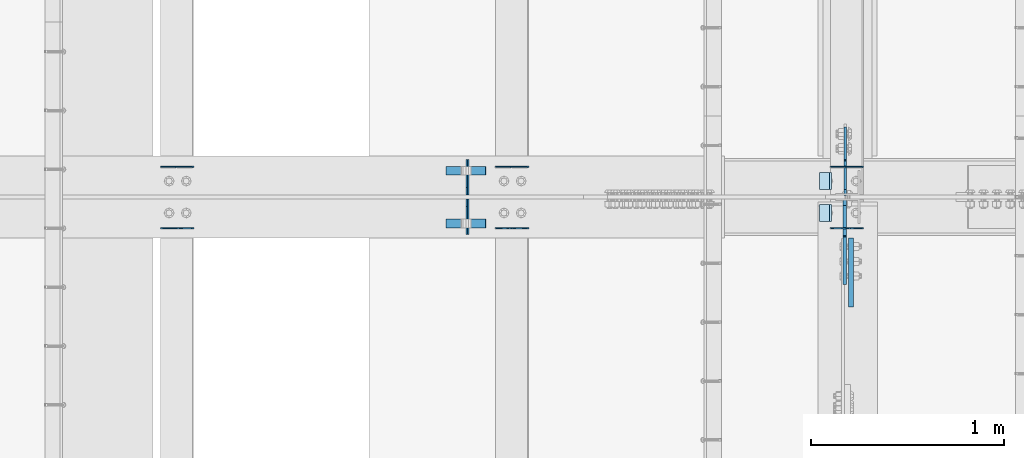
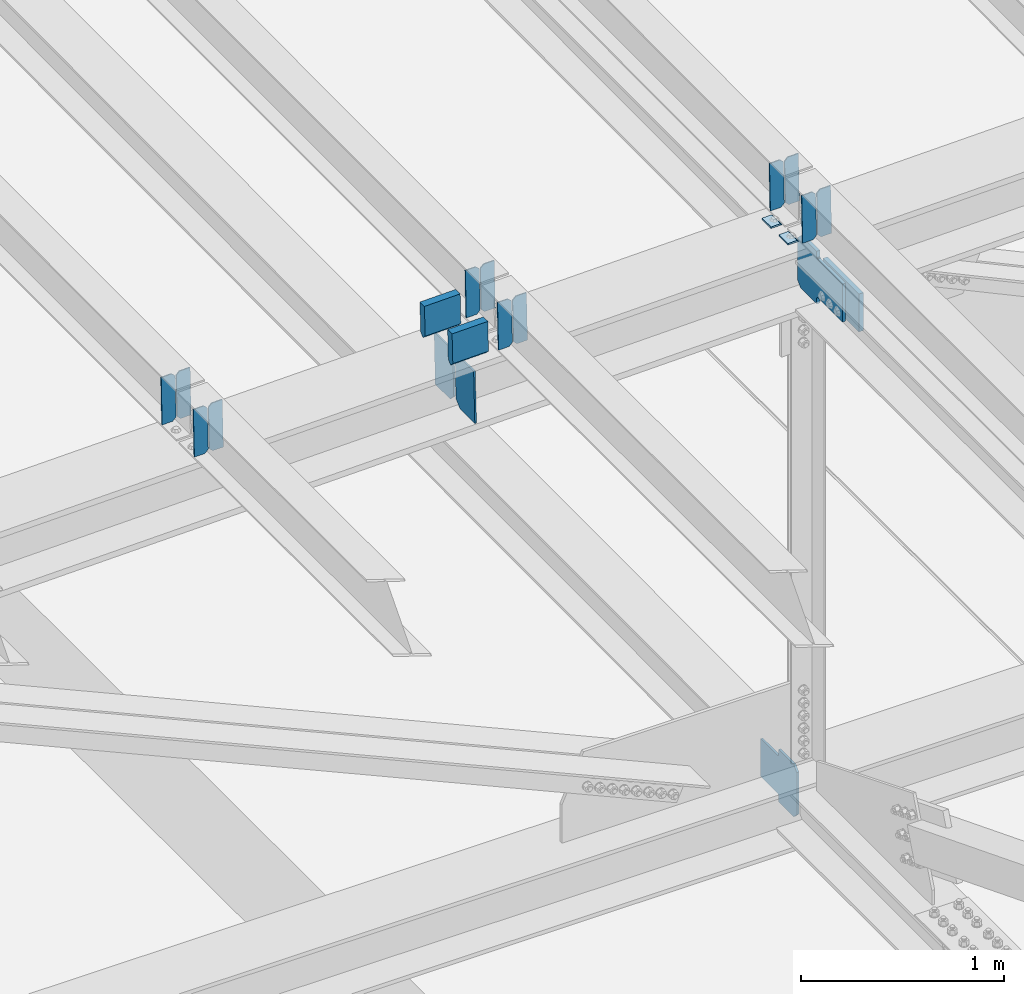
# One storey, part 3289 of 3843: 21 plates, 9 elements without a shape of their own.
"""IFC2X3 building model written with IfcOpenShell, lengths in millimetres."""

from ifc_helpers import new_model, si_unit, frame, origin_with_axes, place, context, subcontext, project, spatial, faceted_brep, material, type_object, element, aggregate, save


model = new_model("IFC2X3")

# Units and contexts
model_context = context("Model", 3, precision=1e-05, world=origin_with_axes())
body_context = subcontext(model_context, "Body", "Model", "MODEL_VIEW")
ifc_project = project(units=[si_unit("LENGTHUNIT", "METRE", prefix="MILLI"), si_unit("AREAUNIT", "SQUARE_METRE"), si_unit("VOLUMEUNIT", "CUBIC_METRE"), si_unit("MASSUNIT", "GRAM", prefix="KILO"), si_unit("TIMEUNIT", "SECOND"), si_unit("PLANEANGLEUNIT", "RADIAN"), si_unit("SOLIDANGLEUNIT", "STERADIAN"), si_unit("THERMODYNAMICTEMPERATUREUNIT", "DEGREE_CELSIUS"), si_unit("LUMINOUSINTENSITYUNIT", "LUMEN")], contexts=[model_context])

# Site, building, storey
site_placement = place(None, origin_with_axes())
site = spatial("IfcSite", under=ifc_project, at=site_placement, CompositionType="ELEMENT")
building_placement = place(site_placement, origin_with_axes())
building = spatial("IfcBuilding", under=site, at=building_placement, Name="Undefined", CompositionType="ELEMENT")
storey_placement = place(building_placement, origin_with_axes())
storey = spatial("IfcBuildingStorey", under=building, at=storey_placement, Name="Undefined", CompositionType="ELEMENT", Elevation=0.0)

# Assembly, plates
assembly_1_placement = place(storey_placement, origin_with_axes())
assembly_1 = element("IfcElementAssembly", 1, at=assembly_1_placement, inside=storey, Name="BEAM", AssemblyPlace="NOTDEFINED", PredefinedType="RIGID_FRAME")
ifc_material = material(Name="STEEL/A572-50")
plate_type_1 = type_object("IfcPlateType", PredefinedType="NOTDEFINED")
plate_1_placement = place(assembly_1_placement, frame((49078.8964783467, 34002.7083470369, 45700.8681200781), z_axis=(-0.0211520981022549, -0.00549162299942689, 0.999761186895503), x_axis=(-0.999776269345233, 0.000116185000071389, -0.0211517790072879)))
plate_1 = element("IfcPlate", 2, at=plate_1_placement, type_object=plate_type_1, material=ifc_material, Name="PLATE", context=body_context, shape_type="Brep", body=[
    faceted_brep([(0.0, -3.17499999999927, 0.0), (6.83940015733242e-10, -3.17499999996653, 288.924999998613), (6.54836185276508e-10, 3.17500000001746, 288.924999998591), (0.0, 3.17499999999927, 0.0), (60.3250007643655, -3.17500000017753, 288.924999998606), (60.3250007643219, 3.17499999979918, 288.924999998584), (79.3750000013097, -3.17500000025029, 269.875000761494), (79.375000001266, 3.17499999972642, 269.875000761487), (79.375000000713, -3.17500000026484, 19.0499992370605), (79.3750000006985, 3.17499999971187, 19.0499992370533), (60.325000763667, -3.17500000020664, -1.45519152283669e-11), (60.3250007636234, 3.17499999977736, -3.63797880709171e-11)], [[[0, 1, 2, 3]], [[1, 4, 5, 2]], [[4, 6, 7, 5]], [[6, 8, 9, 7]], [[8, 10, 11, 9]], [[10, 0, 3, 11]], [[5, 7, 9, 11, 3, 2]], [[10, 8, 6, 4, 1, 0]]]),
])
plate_2_placement = place(assembly_1_placement, frame((48993.1906576571, 34002.7183070254, 45699.0548838318), z_axis=(-0.0211520981022549, -0.00549162299942689, 0.999761186895503), x_axis=(-0.999776269345233, 0.000116185000071389, -0.0211517790072879)))
plate_2 = element("IfcPlate", 3, at=plate_2_placement, type_object=plate_type_1, material=ifc_material, Name="PLATE", context=body_context, shape_type="Brep", body=[
    faceted_brep([(4.36557456851006e-11, -3.17499999998836, 19.0499992370969), (6.11180439591408e-10, -3.17499999996653, 269.875000761516), (5.96628524363041e-10, 3.17500000001746, 269.875000761502), (1.45519152283669e-11, 3.17499999998836, 19.0499992370824), (19.0499992376572, -3.17500000003201, 288.924999998606), (19.0499992376281, 3.1749999999447, 288.924999998584), (79.3750000013242, -3.17500000025029, 288.924999998591), (79.3750000013097, 3.1749999997337, 288.92499999857), (79.3750000006548, -3.17500000026484, -2.18278728425503e-11), (79.3750000006403, 3.17499999969732, -2.91038304567337e-11), (19.0499992370023, -3.17500000005384, 0.0), (19.0499992369587, 3.17499999992287, -1.45519152283669e-11)], [[[0, 1, 2, 3]], [[1, 4, 5, 2]], [[4, 6, 7, 5]], [[6, 8, 9, 7]], [[8, 10, 11, 9]], [[10, 0, 3, 11]], [[5, 7, 9, 11, 3, 2]], [[10, 8, 6, 4, 1, 0]]]),
])

assembly_2_placement = place(storey_placement, origin_with_axes())
assembly_2 = element("IfcElementAssembly", 4, at=assembly_2_placement, inside=storey, Name="BEAM", AssemblyPlace="NOTDEFINED", PredefinedType="RIGID_FRAME")
plate_3_placement = place(assembly_2_placement, frame((49078.8964782632, 33683.7772628472, 45699.8947534283), z_axis=(-0.0211520978689295, -0.000677819999713391, 0.99977603957876), x_axis=(-0.99977626935017, 1.43409999980804e-05, -0.021152093007374)))
plate_3 = element("IfcPlate", 5, at=plate_3_placement, type_object=plate_type_1, material=ifc_material, Name="PLATE", context=body_context, shape_type="Brep", body=[
    faceted_brep([(0.0, -3.17499999999927, 0.0), (6.83940015733242e-10, -3.17499999996653, 288.924999998613), (6.54836185276508e-10, 3.17500000001746, 288.924999998591), (0.0, 3.17499999999927, 0.0), (60.3250007643655, -3.17500000017753, 288.924999998606), (60.3250007643219, 3.17499999979918, 288.924999998584), (79.3750000013097, -3.17500000025029, 269.875000761494), (79.375000001266, 3.17499999972642, 269.875000761487), (79.375000000713, -3.17500000026484, 19.0499992370605), (79.3750000006985, 3.17499999971187, 19.0499992370533), (60.325000763667, -3.17500000020664, -1.45519152283669e-11), (60.3250007636234, 3.17499999977736, -3.63797880709171e-11)], [[[0, 1, 2, 3]], [[1, 4, 5, 2]], [[4, 6, 7, 5]], [[6, 8, 9, 7]], [[8, 10, 11, 9]], [[10, 0, 3, 11]], [[5, 7, 9, 11, 3, 2]], [[10, 8, 6, 4, 1, 0]]]),
])
plate_4_placement = place(assembly_2_placement, frame((48993.1906575735, 33683.7784921894, 45698.0814902443), z_axis=(-0.0211520978689295, -0.000677819999713391, 0.99977603957876), x_axis=(-0.99977626935017, 1.43409999980804e-05, -0.021152093007374)))
plate_4 = element("IfcPlate", 6, at=plate_4_placement, type_object=plate_type_1, material=ifc_material, Name="PLATE", context=body_context, shape_type="Brep", body=[
    faceted_brep([(4.36557456851006e-11, -3.17499999998836, 19.0499992370969), (6.11180439591408e-10, -3.17499999996653, 269.875000761516), (5.96628524363041e-10, 3.17500000001746, 269.875000761502), (1.45519152283669e-11, 3.17499999998836, 19.0499992370824), (19.0499992376572, -3.17500000003201, 288.924999998606), (19.0499992376281, 3.1749999999447, 288.924999998584), (79.3750000013242, -3.17500000025029, 288.924999998591), (79.3750000013097, 3.1749999997337, 288.92499999857), (79.3750000006548, -3.17500000026484, -2.18278728425503e-11), (79.3750000006403, 3.17499999969732, -2.91038304567337e-11), (19.0499992370023, -3.17500000005384, 0.0), (19.0499992369587, 3.17499999992287, -1.45519152283669e-11)], [[[0, 1, 2, 3]], [[1, 4, 5, 2]], [[4, 6, 7, 5]], [[6, 8, 9, 7]], [[8, 10, 11, 9]], [[10, 0, 3, 11]], [[5, 7, 9, 11, 3, 2]], [[10, 8, 6, 4, 1, 0]]]),
])

assembly_3_placement = place(storey_placement, origin_with_axes())
assembly_3 = element("IfcElementAssembly", 7, at=assembly_3_placement, inside=storey, Name="BEAM", AssemblyPlace="NOTDEFINED", PredefinedType="RIGID_FRAME")
plate_5_placement = place(assembly_3_placement, frame((47345.3464782607, 34002.537154914, 45663.263665299), z_axis=(-0.0211520975680761, -0.00491457500028629, 0.999764190057354), x_axis=(-0.999776269348186, 0.0001032410000617, -0.0211518460073737)))
plate_5 = element("IfcPlate", 8, at=plate_5_placement, type_object=plate_type_1, material=ifc_material, Name="PLATE", context=body_context, shape_type="Brep", body=[
    faceted_brep([(0.0, -3.17499999999927, 0.0), (6.83940015733242e-10, -3.17499999996653, 288.924999998613), (6.54836185276508e-10, 3.17500000001746, 288.924999998591), (0.0, 3.17499999999927, 0.0), (60.3250007643655, -3.17500000017753, 288.924999998606), (60.3250007643219, 3.17499999979918, 288.924999998584), (79.3750000013097, -3.17500000025029, 269.875000761494), (79.375000001266, 3.17499999972642, 269.875000761487), (79.375000000713, -3.17500000026484, 19.0499992370605), (79.3750000006985, 3.17499999971187, 19.0499992370533), (60.325000763667, -3.17500000020664, -1.45519152283669e-11), (60.3250007636234, 3.17499999977736, -3.63797880709171e-11)], [[[0, 1, 2, 3]], [[1, 4, 5, 2]], [[4, 6, 7, 5]], [[6, 8, 9, 7]], [[8, 10, 11, 9]], [[10, 0, 3, 11]], [[5, 7, 9, 11, 3, 2]], [[10, 8, 6, 4, 1, 0]]]),
])
plate_6_placement = place(assembly_3_placement, frame((47259.6406575714, 34002.5460683283, 45661.450423606), z_axis=(-0.0211520975680761, -0.00491457500028629, 0.999764190057354), x_axis=(-0.999776269348186, 0.0001032410000617, -0.0211518460073737)))
plate_6 = element("IfcPlate", 9, at=plate_6_placement, type_object=plate_type_1, material=ifc_material, Name="PLATE", context=body_context, shape_type="Brep", body=[
    faceted_brep([(4.36557456851006e-11, -3.17499999998836, 19.0499992370969), (6.11180439591408e-10, -3.17499999996653, 269.875000761516), (5.96628524363041e-10, 3.17500000001746, 269.875000761502), (1.45519152283669e-11, 3.17499999998836, 19.0499992370824), (19.0499992376572, -3.17500000003201, 288.924999998606), (19.0499992376281, 3.1749999999447, 288.924999998584), (79.3750000013242, -3.17500000025029, 288.924999998591), (79.3750000013097, 3.1749999997337, 288.92499999857), (79.3750000006548, -3.17500000026484, -2.18278728425503e-11), (79.3750000006403, 3.17499999969732, -2.91038304567337e-11), (19.0499992370023, -3.17500000005384, 0.0), (19.0499992369587, 3.17499999992287, -1.45519152283669e-11)], [[[0, 1, 2, 3]], [[1, 4, 5, 2]], [[4, 6, 7, 5]], [[6, 8, 9, 7]], [[8, 10, 11, 9]], [[10, 0, 3, 11]], [[5, 7, 9, 11, 3, 2]], [[10, 8, 6, 4, 1, 0]]]),
])
aggregate(assembly_3, [plate_5, plate_6])

assembly_4_placement = place(storey_placement, origin_with_axes())
assembly_4 = element("IfcElementAssembly", 10, at=assembly_4_placement, inside=storey, Name="BEAM", AssemblyPlace="NOTDEFINED", PredefinedType="RIGID_FRAME")
plate_7_placement = place(assembly_4_placement, frame((47345.3464782617, 33683.7417020365, 45662.3995807251), z_axis=(-0.0211520976065004, -0.000583216000144604, 0.999776099247198), x_axis=(-0.999776269355722, 1.23390000256453e-05, -0.0211520940075457)))
plate_7 = element("IfcPlate", 11, at=plate_7_placement, type_object=plate_type_1, material=ifc_material, Name="PLATE", context=body_context, shape_type="Brep", body=[
    faceted_brep([(0.0, -3.17499999999927, 0.0), (6.83940015733242e-10, -3.17499999996653, 288.924999998613), (6.54836185276508e-10, 3.17500000001746, 288.924999998591), (0.0, 3.17499999999927, 0.0), (60.3250007643655, -3.17500000017753, 288.924999998606), (60.3250007643219, 3.17499999979918, 288.924999998584), (79.3750000013097, -3.17500000025029, 269.875000761494), (79.375000001266, 3.17499999972642, 269.875000761487), (79.375000000713, -3.17500000026484, 19.0499992370605), (79.3750000006985, 3.17499999971187, 19.0499992370533), (60.325000763667, -3.17500000020664, -1.45519152283669e-11), (60.3250007636234, 3.17499999977736, -3.63797880709171e-11)], [[[0, 1, 2, 3]], [[1, 4, 5, 2]], [[4, 6, 7, 5]], [[6, 8, 9, 7]], [[8, 10, 11, 9]], [[10, 0, 3, 11]], [[5, 7, 9, 11, 3, 2]], [[10, 8, 6, 4, 1, 0]]]),
])
plate_8_placement = place(assembly_4_placement, frame((47259.6406575723, 33683.7427331328, 45660.5863174178), z_axis=(-0.0211520976065004, -0.000583216000144604, 0.999776099247198), x_axis=(-0.999776269355722, 1.23390000256453e-05, -0.0211520940075457)))
plate_8 = element("IfcPlate", 12, at=plate_8_placement, type_object=plate_type_1, material=ifc_material, Name="PLATE", context=body_context, shape_type="Brep", body=[
    faceted_brep([(4.36557456851006e-11, -3.17499999998836, 19.0499992370969), (6.11180439591408e-10, -3.17499999996653, 269.875000761516), (5.96628524363041e-10, 3.17500000001746, 269.875000761502), (1.45519152283669e-11, 3.17499999998836, 19.0499992370824), (19.0499992376572, -3.17500000003201, 288.924999998606), (19.0499992376281, 3.1749999999447, 288.924999998584), (79.3750000013242, -3.17500000025029, 288.924999998591), (79.3750000013097, 3.1749999997337, 288.92499999857), (79.3750000006548, -3.17500000026484, -2.18278728425503e-11), (79.3750000006403, 3.17499999969732, -2.91038304567337e-11), (19.0499992370023, -3.17500000005384, 0.0), (19.0499992369587, 3.17499999992287, -1.45519152283669e-11)], [[[0, 1, 2, 3]], [[1, 4, 5, 2]], [[4, 6, 7, 5]], [[6, 8, 9, 7]], [[8, 10, 11, 9]], [[10, 0, 3, 11]], [[5, 7, 9, 11, 3, 2]], [[10, 8, 6, 4, 1, 0]]]),
])
aggregate(assembly_4, [plate_7, plate_8])

assembly_5_placement = place(storey_placement, origin_with_axes())
assembly_5 = element("IfcElementAssembly", 13, at=assembly_5_placement, inside=storey, Name="BEAM", AssemblyPlace="NOTDEFINED", PredefinedType="RIGID_FRAME")
plate_9_placement = place(assembly_5_placement, frame((45611.7964782758, 34002.3476221422, 45625.649686956), z_axis=(-0.0211520984749004, -0.00427606199955335, 0.999767124896535), x_axis=(-0.999776269337349, 9.04680000567301e-05, -0.0211519050071807)))
plate_9 = element("IfcPlate", 14, at=plate_9_placement, type_object=plate_type_1, material=ifc_material, Name="PLATE", context=body_context, shape_type="Brep", body=[
    faceted_brep([(0.0, -3.17499999999927, 0.0), (6.83940015733242e-10, -3.17499999996653, 288.924999998613), (6.54836185276508e-10, 3.17500000001746, 288.924999998591), (0.0, 3.17499999999927, 0.0), (60.3250007643655, -3.17500000017753, 288.924999998606), (60.3250007643219, 3.17499999979918, 288.924999998584), (79.3750000013097, -3.17500000025029, 269.875000761494), (79.375000001266, 3.17499999972642, 269.875000761487), (79.375000000713, -3.17500000026484, 19.0499992370605), (79.3750000006985, 3.17499999971187, 19.0499992370533), (60.325000763667, -3.17500000020664, -1.45519152283669e-11), (60.3250007636234, 3.17499999977736, -3.63797880709171e-11)], [[[0, 1, 2, 3]], [[1, 4, 5, 2]], [[4, 6, 7, 5]], [[6, 8, 9, 7]], [[8, 10, 11, 9]], [[10, 0, 3, 11]], [[5, 7, 9, 11, 3, 2]], [[10, 8, 6, 4, 1, 0]]]),
])
plate_10_placement = place(assembly_5_placement, frame((45526.0906575865, 34002.3553775034, 45623.83643994), z_axis=(-0.0211520984749004, -0.00427606199955335, 0.999767124896535), x_axis=(-0.999776269337349, 9.04680000567301e-05, -0.0211519050071807)))
plate_10 = element("IfcPlate", 15, at=plate_10_placement, type_object=plate_type_1, material=ifc_material, Name="PLATE", context=body_context, shape_type="Brep", body=[
    faceted_brep([(4.36557456851006e-11, -3.17499999998836, 19.0499992370969), (6.11180439591408e-10, -3.17499999996653, 269.875000761516), (5.96628524363041e-10, 3.17500000001746, 269.875000761502), (1.45519152283669e-11, 3.17499999998836, 19.0499992370824), (19.0499992376572, -3.17500000003201, 288.924999998606), (19.0499992376281, 3.1749999999447, 288.924999998584), (79.3750000013242, -3.17500000025029, 288.924999998591), (79.3750000013097, 3.1749999997337, 288.92499999857), (79.3750000006548, -3.17500000026484, -2.18278728425503e-11), (79.3750000006403, 3.17499999969732, -2.91038304567337e-11), (19.0499992370023, -3.17500000005384, 0.0), (19.0499992369587, 3.17499999992287, -1.45519152283669e-11)], [[[0, 1, 2, 3]], [[1, 4, 5, 2]], [[4, 6, 7, 5]], [[6, 8, 9, 7]], [[8, 10, 11, 9]], [[10, 0, 3, 11]], [[5, 7, 9, 11, 3, 2]], [[10, 8, 6, 4, 1, 0]]]),
])
aggregate(assembly_5, [plate_9, plate_10])

assembly_6_placement = place(storey_placement, origin_with_axes())
assembly_6 = element("IfcElementAssembly", 16, at=assembly_6_placement, inside=storey, Name="BEAM", AssemblyPlace="NOTDEFINED", PredefinedType="RIGID_FRAME")
plate_11_placement = place(assembly_6_placement, frame((45611.796478263, 33683.7150528755, 45624.9016486398), z_axis=(-0.0211520975334279, -0.000488612999983161, 0.999776149959216), x_axis=(-0.999776269357268, 1.0337000006824e-05, -0.0211520950075907)))
plate_11 = element("IfcPlate", 17, at=plate_11_placement, type_object=plate_type_1, material=ifc_material, Name="PLATE", context=body_context, shape_type="Brep", body=[
    faceted_brep([(0.0, -3.17499999999927, 0.0), (6.83940015733242e-10, -3.17499999996653, 288.924999998613), (6.54836185276508e-10, 3.17500000001746, 288.924999998591), (0.0, 3.17499999999927, 0.0), (60.3250007643655, -3.17500000017753, 288.924999998606), (60.3250007643219, 3.17499999979918, 288.924999998584), (79.3750000013097, -3.17500000025029, 269.875000761494), (79.375000001266, 3.17499999972642, 269.875000761487), (79.375000000713, -3.17500000026484, 19.0499992370605), (79.3750000006985, 3.17499999971187, 19.0499992370533), (60.325000763667, -3.17500000020664, -1.45519152283669e-11), (60.3250007636234, 3.17499999977736, -3.63797880709171e-11)], [[[0, 1, 2, 3]], [[1, 4, 5, 2]], [[4, 6, 7, 5]], [[6, 8, 9, 7]], [[8, 10, 11, 9]], [[10, 0, 3, 11]], [[5, 7, 9, 11, 3, 2]], [[10, 8, 6, 4, 1, 0]]]),
])
plate_12_placement = place(assembly_6_placement, frame((45526.0906575737, 33683.7159167164, 45623.0883852447), z_axis=(-0.0211520975334279, -0.000488612999983161, 0.999776149959216), x_axis=(-0.999776269357268, 1.0337000006824e-05, -0.0211520950075907)))
plate_12 = element("IfcPlate", 18, at=plate_12_placement, type_object=plate_type_1, material=ifc_material, Name="PLATE", context=body_context, shape_type="Brep", body=[
    faceted_brep([(4.36557456851006e-11, -3.17499999998836, 19.0499992370969), (6.11180439591408e-10, -3.17499999996653, 269.875000761516), (5.96628524363041e-10, 3.17500000001746, 269.875000761502), (1.45519152283669e-11, 3.17499999998836, 19.0499992370824), (19.0499992376572, -3.17500000003201, 288.924999998606), (19.0499992376281, 3.1749999999447, 288.924999998584), (79.3750000013242, -3.17500000025029, 288.924999998591), (79.3750000013097, 3.1749999997337, 288.92499999857), (79.3750000006548, -3.17500000026484, -2.18278728425503e-11), (79.3750000006403, 3.17499999969732, -2.91038304567337e-11), (19.0499992370023, -3.17500000005384, 0.0), (19.0499992369587, 3.17499999992287, -1.45519152283669e-11)], [[[0, 1, 2, 3]], [[1, 4, 5, 2]], [[4, 6, 7, 5]], [[6, 8, 9, 7]], [[8, 10, 11, 9]], [[10, 0, 3, 11]], [[5, 7, 9, 11, 3, 2]], [[10, 8, 6, 4, 1, 0]]]),
])
aggregate(assembly_6, [plate_11, plate_12])

assembly_7_placement = place(storey_placement, origin_with_axes())
assembly_7 = element("IfcElementAssembly", 19, at=assembly_7_placement, inside=storey, Name="BEAM", AssemblyPlace="NOTDEFINED", PredefinedType="RIGID_FRAME")
plate_type_2 = type_object("IfcPlateType", PredefinedType="NOTDEFINED")
plate_13_placement = place(assembly_7_placement, frame((47032.0254432563, 33650.2375, 45288.9529776013), z_axis=(-0.0216342480057937, 0.0, 0.999765952267441), x_axis=(0.0, 1.0, 0.0)))
plate_13 = element("IfcPlate", 20, at=plate_13_placement, type_object=plate_type_2, material=ifc_material, Name="PL", context=body_context, shape_type="Brep", body=[
    faceted_brep([(0.0, -4.76249999999709, 0.0), (0.0, -4.76249999785796, 317.500000005042), (0.0, 4.76250000210712, 317.50000000505), (0.0, 4.76249999999709, 0.0), (146.050001525873, -4.76249999785796, 317.500000005042), (146.050001525873, 4.76250000210712, 317.50000000505), (184.149999999994, -4.76249999810534, 279.400001530797), (184.149999999994, 4.76250000185973, 279.400001530805), (184.149999999994, -4.7624999997206, 38.0999984742448), (184.149999999994, 4.76250000022992, 38.0999984742448), (146.049999999988, -4.76250000000073, 0.0), (146.049999999988, 4.76250000000073, 0.0)], [[[0, 1, 2, 3]], [[1, 4, 5, 2]], [[4, 6, 7, 5]], [[6, 8, 9, 7]], [[8, 10, 11, 9]], [[10, 0, 3, 11]], [[5, 7, 9, 11, 3, 2]], [[10, 8, 6, 4, 1, 0]]]),
])
plate_14_placement = place(assembly_7_placement, frame((47032.0254432563, 33856.6125, 45288.9529776013), z_axis=(-0.0216342480057937, 0.0, 0.999765952267441), x_axis=(0.0, 1.0, 0.0)))
plate_14 = element("IfcPlate", 21, at=plate_14_placement, type_object=plate_type_2, material=ifc_material, Name="PL", context=body_context, shape_type="Brep", body=[
    faceted_brep([(0.0, -4.76250000000073, 38.0999999999985), (0.0, -4.76249999810534, 279.400001530797), (0.0, 4.76250000185973, 279.400001530805), (0.0, 4.76250000000073, 38.0999999999985), (38.0999984741211, -4.76249999785796, 317.500000005042), (38.0999984741211, 4.76250000210712, 317.50000000505), (184.150000000009, -4.76249999999709, 317.5), (184.150000000009, 4.76249999999709, 317.5), (184.150000000009, -4.76249999999709, 0.0), (184.150000000009, 4.76249999999709, 0.0), (38.0999984741211, -4.76249999996799, 0.0), (38.0999984741211, 4.76249999998254, 0.0)], [[[0, 1, 2, 3]], [[1, 4, 5, 2]], [[4, 6, 7, 5]], [[6, 8, 9, 7]], [[8, 10, 11, 9]], [[10, 0, 3, 11]], [[5, 7, 9, 11, 3, 2]], [[10, 8, 6, 4, 1, 0]]]),
])
plate_type_3 = type_object("IfcPlateType", PredefinedType="NOTDEFINED")
plate_15_placement = place(assembly_7_placement, frame((46918.6842008661, 33981.628125, 45845.3272449958), z_axis=(0.0217666070074993, 0.0, -0.999763079343992), x_axis=(0.999763079343992, 0.0, 0.0217666070075027)))
plate_15 = element("IfcPlate", 22, at=plate_15_placement, type_object=plate_type_3, material=ifc_material, Name="PLATE", context=body_context, shape_type="Brep", body=[
    faceted_brep([(203.200005058941, -22.2250000000058, -1.16415321826935e-10), (7.27595761418343e-12, -22.2250000000058, -7.27595761418343e-12), (7.27595761418343e-12, 22.2250000000058, -7.27595761418343e-12), (203.200005058941, 22.2250000000058, -1.16415321826935e-10), (203.838531807472, -22.2250000000058, 0.00187068080413155), (203.838531807472, 22.2250000000058, 0.00187068080413155), (203.310341304641, -22.2250000000058, 180.861817383484), (0.04046799018397, -22.2250000000058, 180.907287948779), (203.245434494536, 0.0133131837355904, 203.086833080139), (0.0454396034692763, 0.0133129994646879, 203.132287829787), (0.0404679902494536, 22.2250000000058, 180.907288225317), (203.310341303353, 22.2250000000058, 180.861817822159)], [[[0, 1, 2, 3]], [[4, 0, 3, 5]], [[1, 0, 4, 6, 7]], [[7, 6, 8, 9]], [[2, 1, 7, 9, 10]], [[5, 3, 2, 10, 11]], [[6, 4, 5, 11, 8]], [[10, 9, 8, 11]]]),
])
plate_16_placement = place(assembly_7_placement, frame((46918.6842008661, 33708.578125, 45845.3272449958), z_axis=(0.0217666070074993, 0.0, -0.999763079343992), x_axis=(0.999763079343992, 0.0, 0.0217666070075027)))
plate_16 = element("IfcPlate", 23, at=plate_16_placement, type_object=plate_type_3, material=ifc_material, Name="PLATE", context=body_context, shape_type="Brep", body=[
    faceted_brep([(203.200005058941, -22.2250000000058, -1.16415321826935e-10), (7.27595761418343e-12, -22.2250000000058, -7.27595761418343e-12), (7.27595761418343e-12, 22.2250000000058, -7.27595761418343e-12), (203.200005058941, 22.2250000000058, -1.16415321826935e-10), (203.838531807472, -22.2250000000058, 0.00187068080413155), (203.838531807472, 22.2250000000058, 0.00187068080413155), (203.310341304641, -22.2250000000058, 180.861817383484), (0.04046799018397, -22.2250000000058, 180.907287948779), (203.245434494536, 0.0133131837355904, 203.086833080139), (0.0454396034692763, 0.0133129994646879, 203.132287829787), (0.0404679902494536, 22.2250000000058, 180.907288225317), (203.310341303353, 22.2250000000058, 180.861817822159)], [[[0, 1, 2, 3]], [[4, 0, 3, 5]], [[1, 0, 4, 6, 7]], [[7, 6, 8, 9]], [[2, 1, 7, 9, 10]], [[5, 3, 2, 10, 11]], [[6, 4, 5, 11, 8]], [[10, 9, 8, 11]]]),
])

# Plate
plate_type_4 = type_object("IfcPlateType", PredefinedType="NOTDEFINED")
plate_17_placement = place(assembly_1_placement, frame((48913.9676834261, 33972.4999999999, 45690.1659720332), z_axis=(0.0, -1.0, 0.0), x_axis=(-0.999776270257024, 0.0, -0.0211520550054595)))
plate_17 = element("IfcPlate", 24, at=plate_17_placement, type_object=plate_type_4, material=ifc_material, Name="PLATE", context=body_context, shape_type="Brep", body=[
    faceted_brep([(9.52499999982683, -4.7625000001135, 88.8999999999942), (0.0, 4.76249999999709, 88.9000015258789), (0.0, 4.76249999999709, 0.0), (9.52499999981956, -4.76249999999709, 0.0), (63.4999984608512, -4.76249999988795, 88.8999999999796), (63.4999984608367, -4.76249999988795, -1.45519152283669e-11), (63.4999984608221, 4.76250000013533, -1.45519152283669e-11), (63.4999984608367, 4.76250000013533, 88.8999999999796)], [[[0, 1, 2, 3]], [[4, 5, 6, 7]], [[5, 4, 0, 3]], [[6, 5, 3, 2]], [[7, 6, 2, 1]], [[4, 7, 1, 0]]]),
])

aggregate(assembly_1, [plate_1, plate_2, plate_17])

plate_18_placement = place(assembly_2_placement, frame((48913.9676834261, 33807.4000015258, 45690.1659720332), z_axis=(0.0, -1.0, 0.0), x_axis=(-0.999776270257024, 0.0, -0.0211520550054595)))
plate_18 = element("IfcPlate", 25, at=plate_18_placement, type_object=plate_type_4, material=ifc_material, Name="PLATE", context=body_context, shape_type="Brep", body=[
    faceted_brep([(9.52499999982683, -4.7625000001135, 88.8999999999942), (0.0, 4.76249999999709, 88.9000015258789), (0.0, 4.76249999999709, 0.0), (9.52499999981956, -4.76249999999709, 0.0), (63.4999984608512, -4.76249999988795, 88.8999999999796), (63.4999984608367, -4.76249999988795, -1.45519152283669e-11), (63.4999984608221, 4.76250000013533, -1.45519152283669e-11), (63.4999984608367, 4.76250000013533, 88.8999999999796)], [[[0, 1, 2, 3]], [[4, 5, 6, 7]], [[5, 4, 0, 3]], [[6, 5, 3, 2]], [[7, 6, 2, 1]], [[4, 7, 1, 0]]]),
])

aggregate(assembly_2, [plate_3, plate_4, plate_18])

# Assembly, plate
assembly_8_placement = place(storey_placement, origin_with_axes())
assembly_8 = element("IfcElementAssembly", 26, at=assembly_8_placement, inside=storey, Name="BEAM", AssemblyPlace="NOTDEFINED", PredefinedType="RIGID_FRAME")
plate_type_5 = type_object("IfcPlateType", PredefinedType="NOTDEFINED")
plate_19_placement = place(assembly_8_placement, frame((48985.4874999439, 33852.64375, 42125.5445343741), z_axis=(0.0, 0.707106781186548, 0.707106781186548), x_axis=(5.70000238222118e-08, 0.707106781186546, -0.707106781186546)))
plate_19 = element("IfcPlate", 27, at=plate_19_placement, type_object=plate_type_5, material=ifc_material, Name="PLATE", context=body_context, shape_type="Brep", body=[
    faceted_brep([(0.0, -6.3499999046162, 0.0), (-179.600813047069, -6.35000000000582, 179.600813047073), (-179.600813047069, 6.35000000000582, 179.600813047073), (7.27595761418343e-12, 6.3499999046162, 0.0), (-179.600813047073, -6.35000000000582, 224.502093652191), (-179.600813047073, 6.35000000000582, 224.502093652191), (-75.7666016477051, -6.35000000000582, 328.336305051562), (-75.7666016477051, 6.35000000000582, 328.336305051562), (-54.2654183481573, -6.34999999999854, 306.835121764823), (-54.2654183481573, 6.34999999999854, 306.835121764823), (-50.1452418800109, -6.34999999999854, 304.082107864357), (-50.1452418800109, 6.34999999999854, 304.082107864357), (-45.285162361979, -6.34999999999854, 303.115377941765), (-45.285162361979, 6.34999999999854, 303.115377941765), (-40.4250828439472, -6.34999999999854, 304.082107864357), (-40.4250828439472, 6.34999999999854, 304.082107864357), (-36.3049063758008, -6.34999999999854, 306.835121764823), (-36.3049063758008, 6.34999999999854, 306.835121764823), (80.4384233285746, -6.34999999999854, 423.578451469206), (80.4384233285746, 6.34999999999854, 423.578451469206), (242.083033507046, -6.34999999999854, 261.933841290738), (242.083033507046, 6.34999999999854, 261.933841290738), (125.339703802671, -6.34999999999854, 145.190511586348), (125.339703802671, 6.34999999999854, 145.190511586348), (122.5866899022, -6.34999999999854, 141.070335118209), (122.5866899022, 6.34999999999854, 141.070335118209), (121.619959979613, -6.34999999999854, 136.210255600177), (121.619959979613, 6.34999999999854, 136.210255600177), (122.5866899022, -6.34999999999854, 131.350176082145), (122.5866899022, 6.34999999999854, 131.350176082145), (125.339703802671, -6.34999999999854, 127.229999614006), (125.339703802671, 6.34999999999854, 127.229999614006), (148.735492004496, -6.35000000000582, 103.834211399357), (148.735492004496, 6.35000000000582, 103.834211399357), (44.9012806051323, -6.35000000000582, -1.45519152283669e-11), (44.9012806051323, 6.35000000000582, -1.45519152283669e-11)], [[[0, 1, 2, 3]], [[1, 4, 5, 2]], [[4, 6, 7, 5]], [[6, 8, 9, 7]], [[8, 10, 11, 9]], [[10, 12, 13, 11]], [[12, 14, 15, 13]], [[14, 16, 17, 15]], [[16, 18, 19, 17]], [[18, 20, 21, 19]], [[20, 22, 23, 21]], [[22, 24, 25, 23]], [[24, 26, 27, 25]], [[26, 28, 29, 27]], [[28, 30, 31, 29]], [[30, 32, 33, 31]], [[32, 34, 35, 33]], [[34, 0, 3, 35]], [[5, 7, 9, 11, 13, 15, 17, 19, 21, 23, 25, 27, 29, 31, 33, 35, 3, 2]], [[34, 32, 30, 28, 26, 24, 22, 20, 18, 16, 14, 12, 10, 8, 6, 4, 1, 0]]]),
])
aggregate(assembly_8, [plate_19])

# Plate
plate_type_6 = type_object("IfcPlateType", PredefinedType="NOTDEFINED")
plate_20_placement = place(assembly_7_placement, frame((48982.3124996025, 33834.3875, 45363.111595788), z_axis=(0.0, -0.707106781186682, 0.707106781186413), x_axis=(0.0, -0.707106781186548, -0.707106781186548)))
plate_20 = element("IfcPlate", 28, at=plate_20_placement, type_object=plate_type_6, material=ifc_material, Name="PLATE", context=body_context, shape_type="Brep", body=[
    faceted_brep([(0.0, -9.52500000000146, 0.0), (-179.366715657274, -9.52499999999418, 179.366715657248), (-179.366715657274, 9.52499999999418, 179.366715657248), (0.0, 9.52500000000146, 0.0), (-179.366715656826, -9.52499999999418, 224.267996262832), (-179.366715656826, 9.52499999999418, 224.267996262832), (-68.2360461568533, -9.52499999999418, 335.398665762827), (-68.2360461568533, 9.52499999999418, 335.398665762827), (-46.1232264977771, -9.52499999999418, 313.285846103783), (-46.1232264977771, 9.52499999999418, 313.285846103783), (-42.003050029638, -9.52499999999418, 310.532832203317), (-42.003050029638, 9.52499999999418, 310.532832203317), (-37.1429705115806, -9.52499999999418, 309.566102280762), (-37.1429705115806, 9.52499999999418, 309.566102280762), (-32.2828909935233, -9.52499999999418, 310.53283220336), (-32.2828909935233, 9.52499999999418, 310.53283220336), (-28.1627145253442, -9.52499999999418, 313.28584610387), (-28.1627145253442, 9.52499999999418, 313.28584610387), (142.462151912587, -9.52499999999418, 483.910712541838), (142.462151912587, 9.52499999999418, 483.910712541838), (304.106762091076, -9.52499999999418, 322.266102363385), (304.106762091076, 9.52499999999418, 322.266102363385), (133.481895653153, -9.52499999999418, 151.641235925432), (133.481895653153, 9.52499999999418, 151.641235925432), (130.728881752639, -9.52499999999418, 147.521059457242), (130.728881752639, 9.52499999999418, 147.521059457242), (129.762151830029, -9.52499999999418, 142.660979939188), (129.762151830029, 9.52499999999418, 142.660979939188), (130.728881752595, -9.52499999999418, 137.80090042112), (130.728881752595, 9.52499999999418, 137.80090042112), (133.481895653069, -9.52499999999418, 133.680723952973), (133.481895653069, 9.52499999999418, 133.680723952973), (156.031950102854, -9.52499999999418, 111.130669497732), (156.031950102854, 9.52499999999418, 111.130669497732), (44.9012806055835, -9.52499999999418, 4.65661287307739e-10), (44.9012806055835, 9.52499999999418, 4.65661287307739e-10)], [[[0, 1, 2, 3]], [[1, 4, 5, 2]], [[4, 6, 7, 5]], [[6, 8, 9, 7]], [[8, 10, 11, 9]], [[10, 12, 13, 11]], [[12, 14, 15, 13]], [[14, 16, 17, 15]], [[16, 18, 19, 17]], [[18, 20, 21, 19]], [[20, 22, 23, 21]], [[22, 24, 25, 23]], [[24, 26, 27, 25]], [[26, 28, 29, 27]], [[28, 30, 31, 29]], [[30, 32, 33, 31]], [[32, 34, 35, 33]], [[34, 0, 3, 35]], [[5, 7, 9, 11, 13, 15, 17, 19, 21, 23, 25, 27, 29, 31, 33, 35, 3, 2]], [[34, 32, 30, 28, 26, 24, 22, 20, 18, 16, 14, 12, 10, 8, 6, 4, 1, 0]]]),
])

aggregate(assembly_7, [plate_13, plate_14, plate_15, plate_16, plate_20])

# Assembly, plate
assembly_9_placement = place(storey_placement, origin_with_axes())
assembly_9 = element("IfcElementAssembly", 29, at=assembly_9_placement, inside=storey, Name="BEAM", AssemblyPlace="NOTDEFINED", PredefinedType="RIGID_FRAME")
plate_type_7 = type_object("IfcPlateType", PredefinedType="NOTDEFINED")
plate_21_placement = place(assembly_9_placement, frame((49014.0624913842, 33277.1750151263, 45375.9521877372), z_axis=(0.0, 1.0, 0.0), x_axis=(0.0, 0.0, 1.0)))
plate_21 = element("IfcPlate", 30, at=plate_21_placement, type_object=plate_type_7, material=ifc_material, Name="PLATE", context=body_context, shape_type="Brep", body=[
    faceted_brep([(0.0, -12.6999999999971, 0.0), (0.0, -12.7000000000007, 355.600000000006), (0.0, 12.7000000000007, 355.600000000006), (0.0, 12.6999999999971, 0.0), (228.599998464349, -12.7000000013795, 355.599999691767), (228.599998464349, 12.6999999986292, 355.599999691869), (228.599999999991, -12.7000007629103, -5.82076609134674e-10), (228.59998398881, 12.6999999999971, -9.82254277914762e-10)], [[[0, 1, 2, 3]], [[1, 4, 5, 2]], [[4, 6, 7, 5]], [[6, 0, 3, 7]], [[5, 7, 3, 2]], [[6, 4, 1, 0]]]),
])
aggregate(assembly_9, [plate_21])

save(model, "model.ifc")
